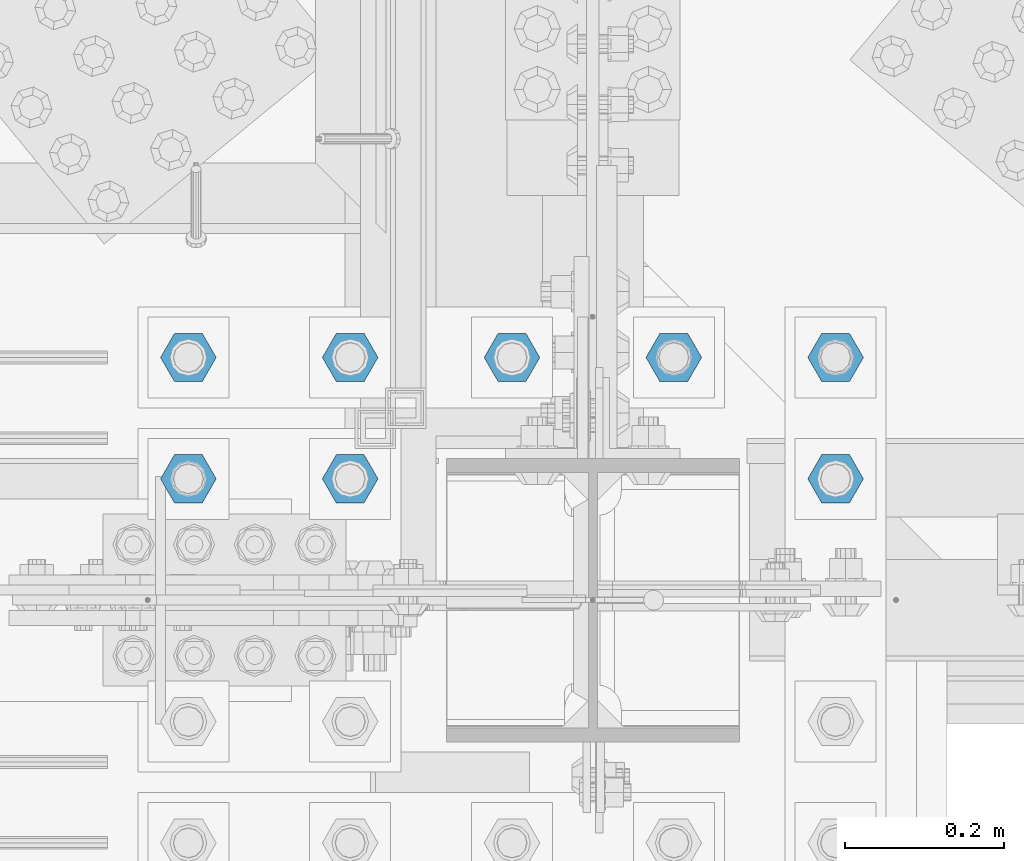
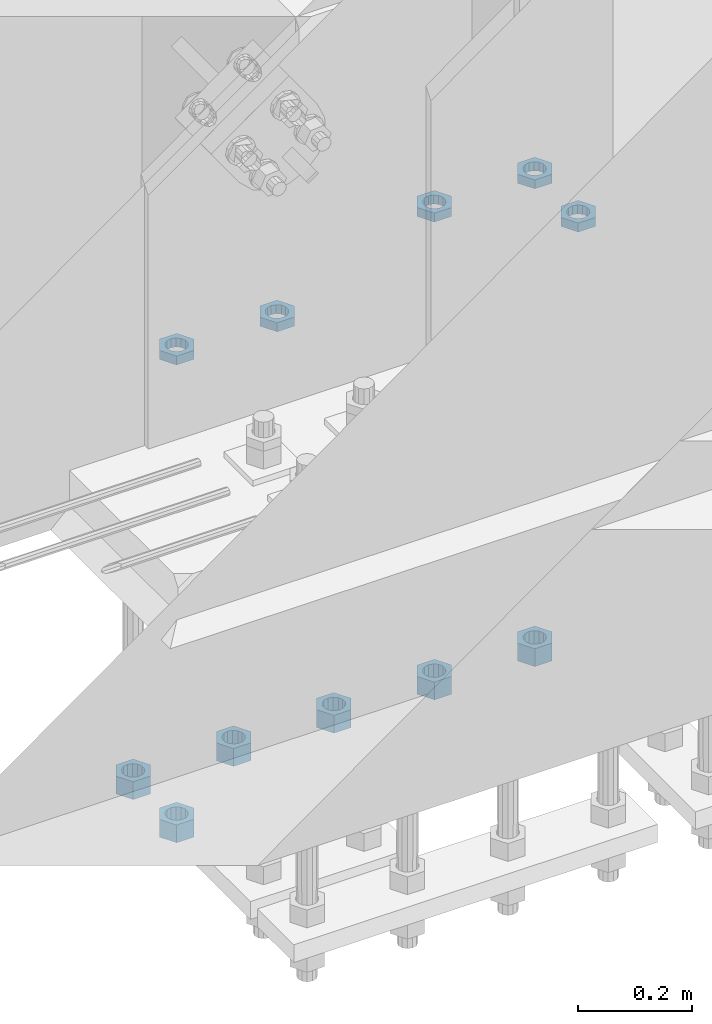
# One storey, part 2819 of 3843: 11 beams, 1 element without a shape of its own.
"""IFC2X3 building model written with IfcOpenShell, lengths in millimetres."""

from ifc_helpers import new_model, si_unit, frame, origin_with_axes, place, context, subcontext, project, spatial, faceted_brep, material, type_object, element, aggregate, save


model = new_model("IFC2X3")

# Units and contexts
model_context = context("Model", 3, precision=1e-05, world=origin_with_axes())
body_context = subcontext(model_context, "Body", "Model", "MODEL_VIEW")
ifc_project = project(units=[si_unit("LENGTHUNIT", "METRE", prefix="MILLI"), si_unit("AREAUNIT", "SQUARE_METRE"), si_unit("VOLUMEUNIT", "CUBIC_METRE"), si_unit("MASSUNIT", "GRAM", prefix="KILO"), si_unit("TIMEUNIT", "SECOND"), si_unit("PLANEANGLEUNIT", "RADIAN"), si_unit("SOLIDANGLEUNIT", "STERADIAN"), si_unit("THERMODYNAMICTEMPERATUREUNIT", "DEGREE_CELSIUS"), si_unit("LUMINOUSINTENSITYUNIT", "LUMEN")], contexts=[model_context])

# Site, building, storey
site_placement = place(None, origin_with_axes())
site = spatial("IfcSite", under=ifc_project, at=site_placement, CompositionType="ELEMENT")
building_placement = place(site_placement, origin_with_axes())
building = spatial("IfcBuilding", under=site, at=building_placement, Name="Undefined", CompositionType="ELEMENT")
storey_placement = place(building_placement, origin_with_axes())
storey = spatial("IfcBuildingStorey", under=building, at=storey_placement, Name="Undefined", CompositionType="ELEMENT", Elevation=0.0)

# Assembly, beams
assembly_placement = place(storey_placement, origin_with_axes())
assembly = element("IfcElementAssembly", 1, at=assembly_placement, inside=storey, Name="TEMPLATE", AssemblyPlace="NOTDEFINED", PredefinedType="RIGID_FRAME")
ifc_material = material(Name="STEEL/A572-50")
beam_type_1 = type_object("IfcBeamType", Name="1-1/2_HEAVY_HEX_NUT", PredefinedType="NOTDEFINED")
beam_1_placement = place(assembly_placement, frame((48488.6, 25768.3, 28746.4500015259), z_axis=(0.0, 1.0, 0.0), x_axis=(0.0, 0.0, -1.0)))
beam_1 = element("IfcBeam", 2, at=beam_1_placement, type_object=beam_type_1, material=ifc_material, Name="NUT", ObjectType="1-1/2_HEAVY_HEX_NUT", context=body_context, shape_type="Brep", body=[
    faceted_brep([(0.0, -34.9199981689453, 0.0), (0.0, -17.4599990844727, -30.25), (38.0999999999985, -17.4599990844727, -30.25), (38.0999999999985, -34.9199981689453, 0.0), (0.0, 17.4599990844727, -30.25), (38.0999999999985, 17.4599990844727, -30.25), (0.0, 34.9199981689453, 0.0), (38.0999999999985, 34.9199981689453, 0.0), (0.0, 17.4599990844727, 30.25), (38.0999999999985, 17.4599990844727, 30.25), (0.0, -17.4599990844727, 30.25), (38.0999999999985, -17.4599990844727, 30.25), (0.0, 0.0, 20.6399993896484), (0.0, 8.9553601105581, 18.5959968835959), (38.0999999999985, 8.9553601105581, 18.5959968835959), (38.0999999999985, 0.0, 20.6399993896484), (0.0, 16.1370013209525, 12.8688291298167), (38.0999999999985, 16.1370013209525, 12.8688291298167), (0.0, 20.1225115123816, 4.59283194104501), (38.0999999999985, 20.1225115123816, 4.59283194104501), (0.0, 20.1225115123816, -4.59283194104501), (38.0999999999985, 20.1225115123816, -4.59283194104501), (0.0, 16.1370013209525, -12.8688291298167), (38.0999999999985, 16.1370013209525, -12.8688291298167), (0.0, 8.9553601105581, -18.5959968835959), (38.0999999999985, 8.9553601105581, -18.5959968835959), (0.0, 0.0, -20.6399993896484), (38.0999999999985, 0.0, -20.6399993896484), (0.0, -8.9553601105581, -18.5959968835959), (38.0999999999985, -8.9553601105581, -18.5959968835959), (0.0, -16.1370013209525, -12.8688291298167), (38.0999999999985, -16.1370013209525, -12.8688291298167), (0.0, -20.1225115123816, -4.59283194104501), (38.0999999999985, -20.1225115123816, -4.59283194104501), (0.0, -20.1225115123816, 4.59283194104501), (38.0999999999985, -20.1225115123816, 4.59283194104501), (0.0, -16.1370013209525, 12.8688291298167), (38.0999999999985, -16.1370013209525, 12.8688291298167), (0.0, -8.9553601105581, 18.5959968835959), (38.0999999999985, -8.9553601105581, 18.5959968835959)], [[[0, 1, 2, 3]], [[1, 4, 5, 2]], [[4, 6, 7, 5]], [[6, 8, 9, 7]], [[8, 10, 11, 9]], [[10, 0, 3, 11]], [[12, 13, 14, 15]], [[13, 16, 17, 14]], [[16, 18, 19, 17]], [[18, 20, 21, 19]], [[20, 22, 23, 21]], [[22, 24, 25, 23]], [[24, 26, 27, 25]], [[26, 28, 29, 27]], [[28, 30, 31, 29]], [[30, 32, 33, 31]], [[32, 34, 35, 33]], [[34, 36, 37, 35]], [[36, 38, 39, 37]], [[38, 12, 15, 39]], [[5, 7, 9, 11, 3, 2], [17, 19, 21, 23, 25, 27, 29, 31, 33, 35, 37, 39, 15, 14]], [[10, 8, 6, 4, 1, 0], [38, 36, 34, 32, 30, 28, 26, 24, 22, 20, 18, 16, 13, 12]]]),
])
beam_2_placement = place(assembly_placement, frame((49301.4, 25920.7, 28746.4500015259), z_axis=(0.0, -1.0, 0.0), x_axis=(0.0, 0.0, -1.0)))
beam_2 = element("IfcBeam", 3, at=beam_2_placement, type_object=beam_type_1, material=ifc_material, Name="NUT", ObjectType="1-1/2_HEAVY_HEX_NUT", context=body_context, shape_type="Brep", body=[
    faceted_brep([(0.0, -34.9199981689453, 0.0), (0.0, -17.4599990844727, -30.25), (38.0999999999985, -17.4599990844727, -30.25), (38.0999999999985, -34.9199981689453, 0.0), (0.0, 17.4599990844727, -30.25), (38.0999999999985, 17.4599990844727, -30.25), (0.0, 34.9199981689453, 0.0), (38.0999999999985, 34.9199981689453, 0.0), (0.0, 17.4599990844727, 30.25), (38.0999999999985, 17.4599990844727, 30.25), (0.0, -17.4599990844727, 30.25), (38.0999999999985, -17.4599990844727, 30.25), (0.0, 0.0, 20.6399993896484), (0.0, 8.9553601105581, 18.5959968835959), (38.0999999999985, 8.9553601105581, 18.5959968835959), (38.0999999999985, 0.0, 20.6399993896484), (0.0, 16.1370013209525, 12.8688291298167), (38.0999999999985, 16.1370013209525, 12.8688291298167), (0.0, 20.1225115123816, 4.59283194104501), (38.0999999999985, 20.1225115123816, 4.59283194104501), (0.0, 20.1225115123816, -4.59283194104501), (38.0999999999985, 20.1225115123816, -4.59283194104501), (0.0, 16.1370013209525, -12.8688291298167), (38.0999999999985, 16.1370013209525, -12.8688291298167), (0.0, 8.9553601105581, -18.5959968835959), (38.0999999999985, 8.9553601105581, -18.5959968835959), (0.0, 0.0, -20.6399993896484), (38.0999999999985, 0.0, -20.6399993896484), (0.0, -8.9553601105581, -18.5959968835959), (38.0999999999985, -8.9553601105581, -18.5959968835959), (0.0, -16.1370013209525, -12.8688291298167), (38.0999999999985, -16.1370013209525, -12.8688291298167), (0.0, -20.1225115123816, -4.59283194104501), (38.0999999999985, -20.1225115123816, -4.59283194104501), (0.0, -20.1225115123816, 4.59283194104501), (38.0999999999985, -20.1225115123816, 4.59283194104501), (0.0, -16.1370013209525, 12.8688291298167), (38.0999999999985, -16.1370013209525, 12.8688291298167), (0.0, -8.9553601105581, 18.5959968835959), (38.0999999999985, -8.9553601105581, 18.5959968835959)], [[[0, 1, 2, 3]], [[1, 4, 5, 2]], [[4, 6, 7, 5]], [[6, 8, 9, 7]], [[8, 10, 11, 9]], [[10, 0, 3, 11]], [[12, 13, 14, 15]], [[13, 16, 17, 14]], [[16, 18, 19, 17]], [[18, 20, 21, 19]], [[20, 22, 23, 21]], [[22, 24, 25, 23]], [[24, 26, 27, 25]], [[26, 28, 29, 27]], [[28, 30, 31, 29]], [[30, 32, 33, 31]], [[32, 34, 35, 33]], [[34, 36, 37, 35]], [[36, 38, 39, 37]], [[38, 12, 15, 39]], [[5, 7, 9, 11, 3, 2], [17, 19, 21, 23, 25, 27, 29, 31, 33, 35, 37, 39, 15, 14]], [[10, 8, 6, 4, 1, 0], [38, 36, 34, 32, 30, 28, 26, 24, 22, 20, 18, 16, 13, 12]]]),
])
beam_3_placement = place(assembly_placement, frame((49098.2, 25920.7, 28746.4500015259), z_axis=(0.0, -1.0, 0.0), x_axis=(0.0, 0.0, -1.0)))
beam_3 = element("IfcBeam", 4, at=beam_3_placement, type_object=beam_type_1, material=ifc_material, Name="NUT", ObjectType="1-1/2_HEAVY_HEX_NUT", context=body_context, shape_type="Brep", body=[
    faceted_brep([(0.0, -34.9199981689453, 0.0), (0.0, -17.4599990844727, -30.25), (38.0999999999985, -17.4599990844727, -30.25), (38.0999999999985, -34.9199981689453, 0.0), (0.0, 17.4599990844727, -30.25), (38.0999999999985, 17.4599990844727, -30.25), (0.0, 34.9199981689453, 0.0), (38.0999999999985, 34.9199981689453, 0.0), (0.0, 17.4599990844727, 30.25), (38.0999999999985, 17.4599990844727, 30.25), (0.0, -17.4599990844727, 30.25), (38.0999999999985, -17.4599990844727, 30.25), (0.0, 0.0, 20.6399993896484), (0.0, 8.9553601105581, 18.5959968835959), (38.0999999999985, 8.9553601105581, 18.5959968835959), (38.0999999999985, 0.0, 20.6399993896484), (0.0, 16.1370013209525, 12.8688291298167), (38.0999999999985, 16.1370013209525, 12.8688291298167), (0.0, 20.1225115123816, 4.59283194104501), (38.0999999999985, 20.1225115123816, 4.59283194104501), (0.0, 20.1225115123816, -4.59283194104501), (38.0999999999985, 20.1225115123816, -4.59283194104501), (0.0, 16.1370013209525, -12.8688291298167), (38.0999999999985, 16.1370013209525, -12.8688291298167), (0.0, 8.9553601105581, -18.5959968835959), (38.0999999999985, 8.9553601105581, -18.5959968835959), (0.0, 0.0, -20.6399993896484), (38.0999999999985, 0.0, -20.6399993896484), (0.0, -8.9553601105581, -18.5959968835959), (38.0999999999985, -8.9553601105581, -18.5959968835959), (0.0, -16.1370013209525, -12.8688291298167), (38.0999999999985, -16.1370013209525, -12.8688291298167), (0.0, -20.1225115123816, -4.59283194104501), (38.0999999999985, -20.1225115123816, -4.59283194104501), (0.0, -20.1225115123816, 4.59283194104501), (38.0999999999985, -20.1225115123816, 4.59283194104501), (0.0, -16.1370013209525, 12.8688291298167), (38.0999999999985, -16.1370013209525, 12.8688291298167), (0.0, -8.9553601105581, 18.5959968835959), (38.0999999999985, -8.9553601105581, 18.5959968835959)], [[[0, 1, 2, 3]], [[1, 4, 5, 2]], [[4, 6, 7, 5]], [[6, 8, 9, 7]], [[8, 10, 11, 9]], [[10, 0, 3, 11]], [[12, 13, 14, 15]], [[13, 16, 17, 14]], [[16, 18, 19, 17]], [[18, 20, 21, 19]], [[20, 22, 23, 21]], [[22, 24, 25, 23]], [[24, 26, 27, 25]], [[26, 28, 29, 27]], [[28, 30, 31, 29]], [[30, 32, 33, 31]], [[32, 34, 35, 33]], [[34, 36, 37, 35]], [[36, 38, 39, 37]], [[38, 12, 15, 39]], [[5, 7, 9, 11, 3, 2], [17, 19, 21, 23, 25, 27, 29, 31, 33, 35, 37, 39, 15, 14]], [[10, 8, 6, 4, 1, 0], [38, 36, 34, 32, 30, 28, 26, 24, 22, 20, 18, 16, 13, 12]]]),
])
beam_4_placement = place(assembly_placement, frame((48895.0, 25920.7, 28746.4500015259), z_axis=(0.0, -1.0, 0.0), x_axis=(0.0, 0.0, -1.0)))
beam_4 = element("IfcBeam", 5, at=beam_4_placement, type_object=beam_type_1, material=ifc_material, Name="NUT", ObjectType="1-1/2_HEAVY_HEX_NUT", context=body_context, shape_type="Brep", body=[
    faceted_brep([(0.0, -34.9199981689453, 0.0), (0.0, -17.4599990844727, -30.25), (38.0999999999985, -17.4599990844727, -30.25), (38.0999999999985, -34.9199981689453, 0.0), (0.0, 17.4599990844727, -30.25), (38.0999999999985, 17.4599990844727, -30.25), (0.0, 34.9199981689453, 0.0), (38.0999999999985, 34.9199981689453, 0.0), (0.0, 17.4599990844727, 30.25), (38.0999999999985, 17.4599990844727, 30.25), (0.0, -17.4599990844727, 30.25), (38.0999999999985, -17.4599990844727, 30.25), (0.0, 0.0, 20.6399993896484), (0.0, 8.9553601105581, 18.5959968835959), (38.0999999999985, 8.9553601105581, 18.5959968835959), (38.0999999999985, 0.0, 20.6399993896484), (0.0, 16.1370013209525, 12.8688291298167), (38.0999999999985, 16.1370013209525, 12.8688291298167), (0.0, 20.1225115123816, 4.59283194104501), (38.0999999999985, 20.1225115123816, 4.59283194104501), (0.0, 20.1225115123816, -4.59283194104501), (38.0999999999985, 20.1225115123816, -4.59283194104501), (0.0, 16.1370013209525, -12.8688291298167), (38.0999999999985, 16.1370013209525, -12.8688291298167), (0.0, 8.9553601105581, -18.5959968835959), (38.0999999999985, 8.9553601105581, -18.5959968835959), (0.0, 0.0, -20.6399993896484), (38.0999999999985, 0.0, -20.6399993896484), (0.0, -8.9553601105581, -18.5959968835959), (38.0999999999985, -8.9553601105581, -18.5959968835959), (0.0, -16.1370013209525, -12.8688291298167), (38.0999999999985, -16.1370013209525, -12.8688291298167), (0.0, -20.1225115123816, -4.59283194104501), (38.0999999999985, -20.1225115123816, -4.59283194104501), (0.0, -20.1225115123816, 4.59283194104501), (38.0999999999985, -20.1225115123816, 4.59283194104501), (0.0, -16.1370013209525, 12.8688291298167), (38.0999999999985, -16.1370013209525, 12.8688291298167), (0.0, -8.9553601105581, 18.5959968835959), (38.0999999999985, -8.9553601105581, 18.5959968835959)], [[[0, 1, 2, 3]], [[1, 4, 5, 2]], [[4, 6, 7, 5]], [[6, 8, 9, 7]], [[8, 10, 11, 9]], [[10, 0, 3, 11]], [[12, 13, 14, 15]], [[13, 16, 17, 14]], [[16, 18, 19, 17]], [[18, 20, 21, 19]], [[20, 22, 23, 21]], [[22, 24, 25, 23]], [[24, 26, 27, 25]], [[26, 28, 29, 27]], [[28, 30, 31, 29]], [[30, 32, 33, 31]], [[32, 34, 35, 33]], [[34, 36, 37, 35]], [[36, 38, 39, 37]], [[38, 12, 15, 39]], [[5, 7, 9, 11, 3, 2], [17, 19, 21, 23, 25, 27, 29, 31, 33, 35, 37, 39, 15, 14]], [[10, 8, 6, 4, 1, 0], [38, 36, 34, 32, 30, 28, 26, 24, 22, 20, 18, 16, 13, 12]]]),
])
beam_5_placement = place(assembly_placement, frame((48691.8, 25920.7, 28746.4500015259), z_axis=(0.0, 1.0, 0.0), x_axis=(0.0, 0.0, -1.0)))
beam_5 = element("IfcBeam", 6, at=beam_5_placement, type_object=beam_type_1, material=ifc_material, Name="NUT", ObjectType="1-1/2_HEAVY_HEX_NUT", context=body_context, shape_type="Brep", body=[
    faceted_brep([(0.0, -34.9199981689453, 0.0), (0.0, -17.4599990844727, -30.25), (38.0999999999985, -17.4599990844727, -30.25), (38.0999999999985, -34.9199981689453, 0.0), (0.0, 17.4599990844727, -30.25), (38.0999999999985, 17.4599990844727, -30.25), (0.0, 34.9199981689453, 0.0), (38.0999999999985, 34.9199981689453, 0.0), (0.0, 17.4599990844727, 30.25), (38.0999999999985, 17.4599990844727, 30.25), (0.0, -17.4599990844727, 30.25), (38.0999999999985, -17.4599990844727, 30.25), (0.0, 0.0, 20.6399993896484), (0.0, 8.9553601105581, 18.5959968835959), (38.0999999999985, 8.9553601105581, 18.5959968835959), (38.0999999999985, 0.0, 20.6399993896484), (0.0, 16.1370013209525, 12.8688291298167), (38.0999999999985, 16.1370013209525, 12.8688291298167), (0.0, 20.1225115123816, 4.59283194104501), (38.0999999999985, 20.1225115123816, 4.59283194104501), (0.0, 20.1225115123816, -4.59283194104501), (38.0999999999985, 20.1225115123816, -4.59283194104501), (0.0, 16.1370013209525, -12.8688291298167), (38.0999999999985, 16.1370013209525, -12.8688291298167), (0.0, 8.9553601105581, -18.5959968835959), (38.0999999999985, 8.9553601105581, -18.5959968835959), (0.0, 0.0, -20.6399993896484), (38.0999999999985, 0.0, -20.6399993896484), (0.0, -8.9553601105581, -18.5959968835959), (38.0999999999985, -8.9553601105581, -18.5959968835959), (0.0, -16.1370013209525, -12.8688291298167), (38.0999999999985, -16.1370013209525, -12.8688291298167), (0.0, -20.1225115123816, -4.59283194104501), (38.0999999999985, -20.1225115123816, -4.59283194104501), (0.0, -20.1225115123816, 4.59283194104501), (38.0999999999985, -20.1225115123816, 4.59283194104501), (0.0, -16.1370013209525, 12.8688291298167), (38.0999999999985, -16.1370013209525, 12.8688291298167), (0.0, -8.9553601105581, 18.5959968835959), (38.0999999999985, -8.9553601105581, 18.5959968835959)], [[[0, 1, 2, 3]], [[1, 4, 5, 2]], [[4, 6, 7, 5]], [[6, 8, 9, 7]], [[8, 10, 11, 9]], [[10, 0, 3, 11]], [[12, 13, 14, 15]], [[13, 16, 17, 14]], [[16, 18, 19, 17]], [[18, 20, 21, 19]], [[20, 22, 23, 21]], [[22, 24, 25, 23]], [[24, 26, 27, 25]], [[26, 28, 29, 27]], [[28, 30, 31, 29]], [[30, 32, 33, 31]], [[32, 34, 35, 33]], [[34, 36, 37, 35]], [[36, 38, 39, 37]], [[38, 12, 15, 39]], [[5, 7, 9, 11, 3, 2], [17, 19, 21, 23, 25, 27, 29, 31, 33, 35, 37, 39, 15, 14]], [[10, 8, 6, 4, 1, 0], [38, 36, 34, 32, 30, 28, 26, 24, 22, 20, 18, 16, 13, 12]]]),
])
beam_6_placement = place(assembly_placement, frame((48488.6, 25920.7, 28746.4500015259), z_axis=(0.0, 1.0, 0.0), x_axis=(0.0, 0.0, -1.0)))
beam_6 = element("IfcBeam", 7, at=beam_6_placement, type_object=beam_type_1, material=ifc_material, Name="NUT", ObjectType="1-1/2_HEAVY_HEX_NUT", context=body_context, shape_type="Brep", body=[
    faceted_brep([(0.0, -34.9199981689453, 0.0), (0.0, -17.4599990844727, -30.25), (38.0999999999985, -17.4599990844727, -30.25), (38.0999999999985, -34.9199981689453, 0.0), (0.0, 17.4599990844727, -30.25), (38.0999999999985, 17.4599990844727, -30.25), (0.0, 34.9199981689453, 0.0), (38.0999999999985, 34.9199981689453, 0.0), (0.0, 17.4599990844727, 30.25), (38.0999999999985, 17.4599990844727, 30.25), (0.0, -17.4599990844727, 30.25), (38.0999999999985, -17.4599990844727, 30.25), (0.0, 0.0, 20.6399993896484), (0.0, 8.9553601105581, 18.5959968835959), (38.0999999999985, 8.9553601105581, 18.5959968835959), (38.0999999999985, 0.0, 20.6399993896484), (0.0, 16.1370013209525, 12.8688291298167), (38.0999999999985, 16.1370013209525, 12.8688291298167), (0.0, 20.1225115123816, 4.59283194104501), (38.0999999999985, 20.1225115123816, 4.59283194104501), (0.0, 20.1225115123816, -4.59283194104501), (38.0999999999985, 20.1225115123816, -4.59283194104501), (0.0, 16.1370013209525, -12.8688291298167), (38.0999999999985, 16.1370013209525, -12.8688291298167), (0.0, 8.9553601105581, -18.5959968835959), (38.0999999999985, 8.9553601105581, -18.5959968835959), (0.0, 0.0, -20.6399993896484), (38.0999999999985, 0.0, -20.6399993896484), (0.0, -8.9553601105581, -18.5959968835959), (38.0999999999985, -8.9553601105581, -18.5959968835959), (0.0, -16.1370013209525, -12.8688291298167), (38.0999999999985, -16.1370013209525, -12.8688291298167), (0.0, -20.1225115123816, -4.59283194104501), (38.0999999999985, -20.1225115123816, -4.59283194104501), (0.0, -20.1225115123816, 4.59283194104501), (38.0999999999985, -20.1225115123816, 4.59283194104501), (0.0, -16.1370013209525, 12.8688291298167), (38.0999999999985, -16.1370013209525, 12.8688291298167), (0.0, -8.9553601105581, 18.5959968835959), (38.0999999999985, -8.9553601105581, 18.5959968835959)], [[[0, 1, 2, 3]], [[1, 4, 5, 2]], [[4, 6, 7, 5]], [[6, 8, 9, 7]], [[8, 10, 11, 9]], [[10, 0, 3, 11]], [[12, 13, 14, 15]], [[13, 16, 17, 14]], [[16, 18, 19, 17]], [[18, 20, 21, 19]], [[20, 22, 23, 21]], [[22, 24, 25, 23]], [[24, 26, 27, 25]], [[26, 28, 29, 27]], [[28, 30, 31, 29]], [[30, 32, 33, 31]], [[32, 34, 35, 33]], [[34, 36, 37, 35]], [[36, 38, 39, 37]], [[38, 12, 15, 39]], [[5, 7, 9, 11, 3, 2], [17, 19, 21, 23, 25, 27, 29, 31, 33, 35, 37, 39, 15, 14]], [[10, 8, 6, 4, 1, 0], [38, 36, 34, 32, 30, 28, 26, 24, 22, 20, 18, 16, 13, 12]]]),
])
beam_type_2 = type_object("IfcBeamType", Name="1-1/2_HALF_NUT", PredefinedType="NOTDEFINED")
beam_7_placement = place(assembly_placement, frame((49301.4, 25768.3, 29749.75), z_axis=(0.0, -1.0, 0.0), x_axis=(0.0, 0.0, -1.0)))
beam_7 = element("IfcBeam", 8, at=beam_7_placement, type_object=beam_type_2, material=ifc_material, Name="NUT", ObjectType="1-1/2_HALF_NUT", context=body_context, shape_type="Brep", body=[
    faceted_brep([(0.0, -34.9199981689453, 0.0), (0.0, -17.4599990844727, -30.25), (19.0500000000029, -17.4599990844727, -30.25), (19.0500000000029, -34.9199981689453, 0.0), (0.0, 17.4599990844727, -30.25), (19.0500000000029, 17.4599990844727, -30.25), (0.0, 34.9199981689453, 0.0), (19.0500000000029, 34.9199981689453, 0.0), (0.0, 17.4599990844727, 30.25), (19.0500000000029, 17.4599990844727, 30.25), (0.0, -17.4599990844727, 30.25), (19.0500000000029, -17.4599990844727, 30.25), (0.0, 0.0, 20.6399993896484), (0.0, 8.9553601105581, 18.5959968835959), (19.0500000000029, 8.95536011056538, 18.5959968835959), (19.0500000000029, 0.0, 20.6399993896484), (0.0, 16.1370013209525, 12.8688291298167), (19.0500000000029, 16.1370013209489, 12.8688291298167), (0.0, 20.1225115123816, 4.59283194104501), (19.0500000000029, 20.1225115123852, 4.59283194104501), (0.0, 20.1225115123816, -4.59283194104501), (19.0500000000029, 20.1225115123852, -4.59283194104501), (0.0, 16.1370013209525, -12.8688291298167), (19.0500000000029, 16.1370013209489, -12.8688291298167), (0.0, 8.9553601105581, -18.5959968835959), (19.0500000000029, 8.95536011056538, -18.5959968835959), (0.0, 0.0, -20.6399993896484), (19.0500000000029, 0.0, -20.6399993896484), (0.0, -8.9553601105581, -18.5959968835959), (19.0500000000029, -8.95536011056538, -18.5959968835959), (0.0, -16.1370013209525, -12.8688291298167), (19.0500000000029, -16.1370013209489, -12.8688291298167), (0.0, -20.1225115123816, -4.59283194104501), (19.0500000000029, -20.1225115123852, -4.59283194104501), (0.0, -20.1225115123816, 4.59283194104501), (19.0500000000029, -20.1225115123852, 4.59283194104501), (0.0, -16.1370013209525, 12.8688291298167), (19.0500000000029, -16.1370013209489, 12.8688291298167), (0.0, -8.9553601105581, 18.5959968835959), (19.0500000000029, -8.95536011056538, 18.5959968835959)], [[[0, 1, 2, 3]], [[1, 4, 5, 2]], [[4, 6, 7, 5]], [[6, 8, 9, 7]], [[8, 10, 11, 9]], [[10, 0, 3, 11]], [[12, 13, 14, 15]], [[13, 16, 17, 14]], [[16, 18, 19, 17]], [[18, 20, 21, 19]], [[20, 22, 23, 21]], [[22, 24, 25, 23]], [[24, 26, 27, 25]], [[26, 28, 29, 27]], [[28, 30, 31, 29]], [[30, 32, 33, 31]], [[32, 34, 35, 33]], [[34, 36, 37, 35]], [[36, 38, 39, 37]], [[38, 12, 15, 39]], [[5, 7, 9, 11, 3, 2], [17, 19, 21, 23, 25, 27, 29, 31, 33, 35, 37, 39, 15, 14]], [[10, 8, 6, 4, 1, 0], [38, 36, 34, 32, 30, 28, 26, 24, 22, 20, 18, 16, 13, 12]]]),
])
beam_8_placement = place(assembly_placement, frame((48691.8, 25768.3, 29749.75), z_axis=(0.0, 1.0, 0.0), x_axis=(0.0, 0.0, -1.0)))
beam_8 = element("IfcBeam", 9, at=beam_8_placement, type_object=beam_type_2, material=ifc_material, Name="NUT", ObjectType="1-1/2_HALF_NUT", context=body_context, shape_type="Brep", body=[
    faceted_brep([(0.0, -34.9199981689453, 0.0), (0.0, -17.4599990844727, -30.25), (19.0500000000029, -17.4599990844727, -30.25), (19.0500000000029, -34.9199981689453, 0.0), (0.0, 17.4599990844727, -30.25), (19.0500000000029, 17.4599990844727, -30.25), (0.0, 34.9199981689453, 0.0), (19.0500000000029, 34.9199981689453, 0.0), (0.0, 17.4599990844727, 30.25), (19.0500000000029, 17.4599990844727, 30.25), (0.0, -17.4599990844727, 30.25), (19.0500000000029, -17.4599990844727, 30.25), (0.0, 0.0, 20.6399993896484), (0.0, 8.9553601105581, 18.5959968835959), (19.0500000000029, 8.95536011056538, 18.5959968835959), (19.0500000000029, 0.0, 20.6399993896484), (0.0, 16.1370013209525, 12.8688291298167), (19.0500000000029, 16.1370013209489, 12.8688291298167), (0.0, 20.1225115123816, 4.59283194104501), (19.0500000000029, 20.1225115123852, 4.59283194104501), (0.0, 20.1225115123816, -4.59283194104501), (19.0500000000029, 20.1225115123852, -4.59283194104501), (0.0, 16.1370013209525, -12.8688291298167), (19.0500000000029, 16.1370013209489, -12.8688291298167), (0.0, 8.9553601105581, -18.5959968835959), (19.0500000000029, 8.95536011056538, -18.5959968835959), (0.0, 0.0, -20.6399993896484), (19.0500000000029, 0.0, -20.6399993896484), (0.0, -8.9553601105581, -18.5959968835959), (19.0500000000029, -8.95536011056538, -18.5959968835959), (0.0, -16.1370013209525, -12.8688291298167), (19.0500000000029, -16.1370013209489, -12.8688291298167), (0.0, -20.1225115123816, -4.59283194104501), (19.0500000000029, -20.1225115123852, -4.59283194104501), (0.0, -20.1225115123816, 4.59283194104501), (19.0500000000029, -20.1225115123852, 4.59283194104501), (0.0, -16.1370013209525, 12.8688291298167), (19.0500000000029, -16.1370013209489, 12.8688291298167), (0.0, -8.9553601105581, 18.5959968835959), (19.0500000000029, -8.95536011056538, 18.5959968835959)], [[[0, 1, 2, 3]], [[1, 4, 5, 2]], [[4, 6, 7, 5]], [[6, 8, 9, 7]], [[8, 10, 11, 9]], [[10, 0, 3, 11]], [[12, 13, 14, 15]], [[13, 16, 17, 14]], [[16, 18, 19, 17]], [[18, 20, 21, 19]], [[20, 22, 23, 21]], [[22, 24, 25, 23]], [[24, 26, 27, 25]], [[26, 28, 29, 27]], [[28, 30, 31, 29]], [[30, 32, 33, 31]], [[32, 34, 35, 33]], [[34, 36, 37, 35]], [[36, 38, 39, 37]], [[38, 12, 15, 39]], [[5, 7, 9, 11, 3, 2], [17, 19, 21, 23, 25, 27, 29, 31, 33, 35, 37, 39, 15, 14]], [[10, 8, 6, 4, 1, 0], [38, 36, 34, 32, 30, 28, 26, 24, 22, 20, 18, 16, 13, 12]]]),
])
beam_9_placement = place(assembly_placement, frame((48488.6, 25768.3, 29749.75), z_axis=(0.0, 1.0, 0.0), x_axis=(0.0, 0.0, -1.0)))
beam_9 = element("IfcBeam", 10, at=beam_9_placement, type_object=beam_type_2, material=ifc_material, Name="NUT", ObjectType="1-1/2_HALF_NUT", context=body_context, shape_type="Brep", body=[
    faceted_brep([(0.0, -34.9199981689453, 0.0), (0.0, -17.4599990844727, -30.25), (19.0500000000029, -17.4599990844727, -30.25), (19.0500000000029, -34.9199981689453, 0.0), (0.0, 17.4599990844727, -30.25), (19.0500000000029, 17.4599990844727, -30.25), (0.0, 34.9199981689453, 0.0), (19.0500000000029, 34.9199981689453, 0.0), (0.0, 17.4599990844727, 30.25), (19.0500000000029, 17.4599990844727, 30.25), (0.0, -17.4599990844727, 30.25), (19.0500000000029, -17.4599990844727, 30.25), (0.0, 0.0, 20.6399993896484), (0.0, 8.9553601105581, 18.5959968835959), (19.0500000000029, 8.95536011056538, 18.5959968835959), (19.0500000000029, 0.0, 20.6399993896484), (0.0, 16.1370013209525, 12.8688291298167), (19.0500000000029, 16.1370013209489, 12.8688291298167), (0.0, 20.1225115123816, 4.59283194104501), (19.0500000000029, 20.1225115123852, 4.59283194104501), (0.0, 20.1225115123816, -4.59283194104501), (19.0500000000029, 20.1225115123852, -4.59283194104501), (0.0, 16.1370013209525, -12.8688291298167), (19.0500000000029, 16.1370013209489, -12.8688291298167), (0.0, 8.9553601105581, -18.5959968835959), (19.0500000000029, 8.95536011056538, -18.5959968835959), (0.0, 0.0, -20.6399993896484), (19.0500000000029, 0.0, -20.6399993896484), (0.0, -8.9553601105581, -18.5959968835959), (19.0500000000029, -8.95536011056538, -18.5959968835959), (0.0, -16.1370013209525, -12.8688291298167), (19.0500000000029, -16.1370013209489, -12.8688291298167), (0.0, -20.1225115123816, -4.59283194104501), (19.0500000000029, -20.1225115123852, -4.59283194104501), (0.0, -20.1225115123816, 4.59283194104501), (19.0500000000029, -20.1225115123852, 4.59283194104501), (0.0, -16.1370013209525, 12.8688291298167), (19.0500000000029, -16.1370013209489, 12.8688291298167), (0.0, -8.9553601105581, 18.5959968835959), (19.0500000000029, -8.95536011056538, 18.5959968835959)], [[[0, 1, 2, 3]], [[1, 4, 5, 2]], [[4, 6, 7, 5]], [[6, 8, 9, 7]], [[8, 10, 11, 9]], [[10, 0, 3, 11]], [[12, 13, 14, 15]], [[13, 16, 17, 14]], [[16, 18, 19, 17]], [[18, 20, 21, 19]], [[20, 22, 23, 21]], [[22, 24, 25, 23]], [[24, 26, 27, 25]], [[26, 28, 29, 27]], [[28, 30, 31, 29]], [[30, 32, 33, 31]], [[32, 34, 35, 33]], [[34, 36, 37, 35]], [[36, 38, 39, 37]], [[38, 12, 15, 39]], [[5, 7, 9, 11, 3, 2], [17, 19, 21, 23, 25, 27, 29, 31, 33, 35, 37, 39, 15, 14]], [[10, 8, 6, 4, 1, 0], [38, 36, 34, 32, 30, 28, 26, 24, 22, 20, 18, 16, 13, 12]]]),
])
beam_10_placement = place(assembly_placement, frame((49301.4, 25920.7, 29749.75), z_axis=(0.0, -1.0, 0.0), x_axis=(0.0, 0.0, -1.0)))
beam_10 = element("IfcBeam", 11, at=beam_10_placement, type_object=beam_type_2, material=ifc_material, Name="NUT", ObjectType="1-1/2_HALF_NUT", context=body_context, shape_type="Brep", body=[
    faceted_brep([(0.0, -34.9199981689453, 0.0), (0.0, -17.4599990844727, -30.25), (19.0500000000029, -17.4599990844727, -30.25), (19.0500000000029, -34.9199981689453, 0.0), (0.0, 17.4599990844727, -30.25), (19.0500000000029, 17.4599990844727, -30.25), (0.0, 34.9199981689453, 0.0), (19.0500000000029, 34.9199981689453, 0.0), (0.0, 17.4599990844727, 30.25), (19.0500000000029, 17.4599990844727, 30.25), (0.0, -17.4599990844727, 30.25), (19.0500000000029, -17.4599990844727, 30.25), (0.0, 0.0, 20.6399993896484), (0.0, 8.9553601105581, 18.5959968835959), (19.0500000000029, 8.95536011056538, 18.5959968835959), (19.0500000000029, 0.0, 20.6399993896484), (0.0, 16.1370013209525, 12.8688291298167), (19.0500000000029, 16.1370013209489, 12.8688291298167), (0.0, 20.1225115123816, 4.59283194104501), (19.0500000000029, 20.1225115123852, 4.59283194104501), (0.0, 20.1225115123816, -4.59283194104501), (19.0500000000029, 20.1225115123852, -4.59283194104501), (0.0, 16.1370013209525, -12.8688291298167), (19.0500000000029, 16.1370013209489, -12.8688291298167), (0.0, 8.9553601105581, -18.5959968835959), (19.0500000000029, 8.95536011056538, -18.5959968835959), (0.0, 0.0, -20.6399993896484), (19.0500000000029, 0.0, -20.6399993896484), (0.0, -8.9553601105581, -18.5959968835959), (19.0500000000029, -8.95536011056538, -18.5959968835959), (0.0, -16.1370013209525, -12.8688291298167), (19.0500000000029, -16.1370013209489, -12.8688291298167), (0.0, -20.1225115123816, -4.59283194104501), (19.0500000000029, -20.1225115123852, -4.59283194104501), (0.0, -20.1225115123816, 4.59283194104501), (19.0500000000029, -20.1225115123852, 4.59283194104501), (0.0, -16.1370013209525, 12.8688291298167), (19.0500000000029, -16.1370013209489, 12.8688291298167), (0.0, -8.9553601105581, 18.5959968835959), (19.0500000000029, -8.95536011056538, 18.5959968835959)], [[[0, 1, 2, 3]], [[1, 4, 5, 2]], [[4, 6, 7, 5]], [[6, 8, 9, 7]], [[8, 10, 11, 9]], [[10, 0, 3, 11]], [[12, 13, 14, 15]], [[13, 16, 17, 14]], [[16, 18, 19, 17]], [[18, 20, 21, 19]], [[20, 22, 23, 21]], [[22, 24, 25, 23]], [[24, 26, 27, 25]], [[26, 28, 29, 27]], [[28, 30, 31, 29]], [[30, 32, 33, 31]], [[32, 34, 35, 33]], [[34, 36, 37, 35]], [[36, 38, 39, 37]], [[38, 12, 15, 39]], [[5, 7, 9, 11, 3, 2], [17, 19, 21, 23, 25, 27, 29, 31, 33, 35, 37, 39, 15, 14]], [[10, 8, 6, 4, 1, 0], [38, 36, 34, 32, 30, 28, 26, 24, 22, 20, 18, 16, 13, 12]]]),
])
beam_11_placement = place(assembly_placement, frame((49098.2, 25920.7, 29749.75), z_axis=(0.0, -1.0, 0.0), x_axis=(0.0, 0.0, -1.0)))
beam_11 = element("IfcBeam", 12, at=beam_11_placement, type_object=beam_type_2, material=ifc_material, Name="NUT", ObjectType="1-1/2_HALF_NUT", context=body_context, shape_type="Brep", body=[
    faceted_brep([(0.0, -34.9199981689453, 0.0), (0.0, -17.4599990844727, -30.25), (19.0500000000029, -17.4599990844727, -30.25), (19.0500000000029, -34.9199981689453, 0.0), (0.0, 17.4599990844727, -30.25), (19.0500000000029, 17.4599990844727, -30.25), (0.0, 34.9199981689453, 0.0), (19.0500000000029, 34.9199981689453, 0.0), (0.0, 17.4599990844727, 30.25), (19.0500000000029, 17.4599990844727, 30.25), (0.0, -17.4599990844727, 30.25), (19.0500000000029, -17.4599990844727, 30.25), (0.0, 0.0, 20.6399993896484), (0.0, 8.9553601105581, 18.5959968835959), (19.0500000000029, 8.95536011056538, 18.5959968835959), (19.0500000000029, 0.0, 20.6399993896484), (0.0, 16.1370013209525, 12.8688291298167), (19.0500000000029, 16.1370013209489, 12.8688291298167), (0.0, 20.1225115123816, 4.59283194104501), (19.0500000000029, 20.1225115123852, 4.59283194104501), (0.0, 20.1225115123816, -4.59283194104501), (19.0500000000029, 20.1225115123852, -4.59283194104501), (0.0, 16.1370013209525, -12.8688291298167), (19.0500000000029, 16.1370013209489, -12.8688291298167), (0.0, 8.9553601105581, -18.5959968835959), (19.0500000000029, 8.95536011056538, -18.5959968835959), (0.0, 0.0, -20.6399993896484), (19.0500000000029, 0.0, -20.6399993896484), (0.0, -8.9553601105581, -18.5959968835959), (19.0500000000029, -8.95536011056538, -18.5959968835959), (0.0, -16.1370013209525, -12.8688291298167), (19.0500000000029, -16.1370013209489, -12.8688291298167), (0.0, -20.1225115123816, -4.59283194104501), (19.0500000000029, -20.1225115123852, -4.59283194104501), (0.0, -20.1225115123816, 4.59283194104501), (19.0500000000029, -20.1225115123852, 4.59283194104501), (0.0, -16.1370013209525, 12.8688291298167), (19.0500000000029, -16.1370013209489, 12.8688291298167), (0.0, -8.9553601105581, 18.5959968835959), (19.0500000000029, -8.95536011056538, 18.5959968835959)], [[[0, 1, 2, 3]], [[1, 4, 5, 2]], [[4, 6, 7, 5]], [[6, 8, 9, 7]], [[8, 10, 11, 9]], [[10, 0, 3, 11]], [[12, 13, 14, 15]], [[13, 16, 17, 14]], [[16, 18, 19, 17]], [[18, 20, 21, 19]], [[20, 22, 23, 21]], [[22, 24, 25, 23]], [[24, 26, 27, 25]], [[26, 28, 29, 27]], [[28, 30, 31, 29]], [[30, 32, 33, 31]], [[32, 34, 35, 33]], [[34, 36, 37, 35]], [[36, 38, 39, 37]], [[38, 12, 15, 39]], [[5, 7, 9, 11, 3, 2], [17, 19, 21, 23, 25, 27, 29, 31, 33, 35, 37, 39, 15, 14]], [[10, 8, 6, 4, 1, 0], [38, 36, 34, 32, 30, 28, 26, 24, 22, 20, 18, 16, 13, 12]]]),
])
aggregate(assembly, [beam_1, beam_2, beam_3, beam_4, beam_5, beam_6, beam_7, beam_8, beam_9, beam_10, beam_11])

save(model, "model.ifc")
